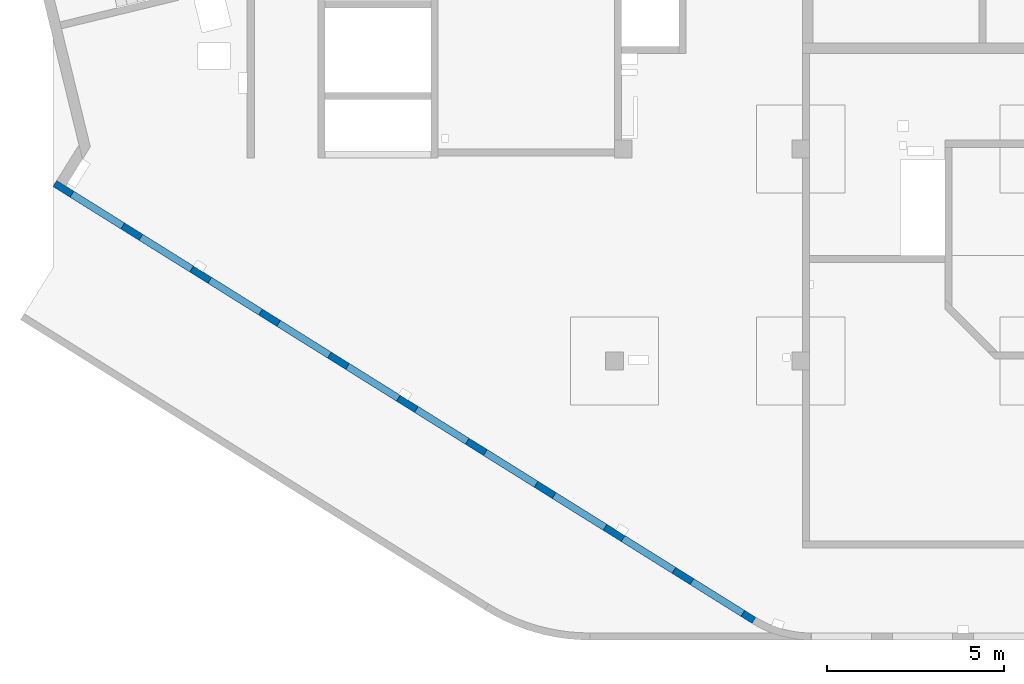
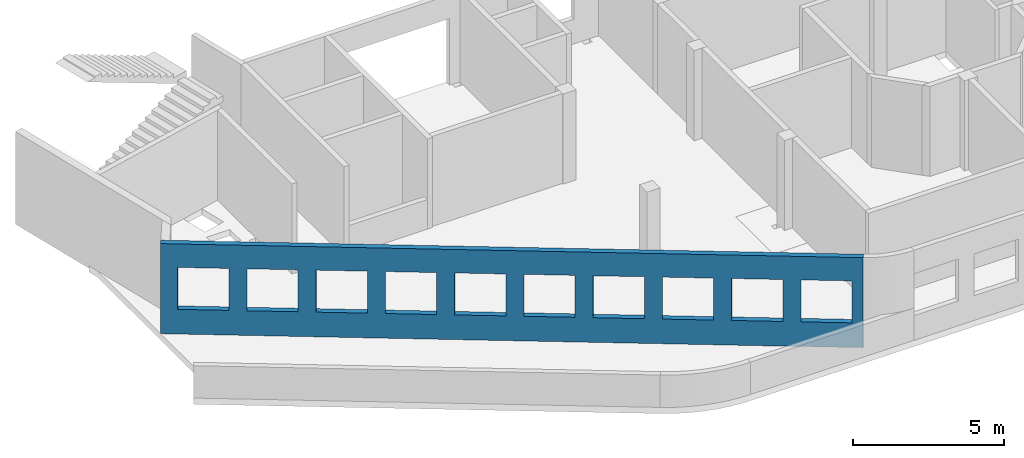
# One storey, part 7 of 10: 1 wall, 10 openings.
"""IFC4 building model written with IfcOpenShell, lengths in millimetres."""

from ifc_helpers import new_model, entity, si_unit, converted_unit, derived_unit, direction, frame, origin, place, context, subcontext, project, spatial, indexed_curve, outline, extrude, polygons, material, type_object, element, save


model = new_model("IFC4")

# Units and contexts
model_context = context("Model", 3, precision=0.01, world=origin(), true_north=direction((6.12303176911189e-17, 1.0)))
plan_context = context("Plan", 3, precision=0.01, world=origin(), true_north=direction((6.12303176911189e-17, 1.0)))
body_context = subcontext(model_context, "Body", "Model", "MODEL_VIEW")
ifc_project = project(units=[si_unit("LENGTHUNIT", "METRE", prefix="MILLI"), si_unit("AREAUNIT", "SQUARE_METRE"), si_unit("VOLUMEUNIT", "CUBIC_METRE"), converted_unit("PLANEANGLEUNIT", "DEGREE", entity("IfcRatioMeasure", 0.0174532925199433), si_unit("PLANEANGLEUNIT", "RADIAN"), dimensions=[0, 0, 0, 0, 0, 0, 0]), si_unit("MASSUNIT", "GRAM", prefix="KILO"), derived_unit("MASSDENSITYUNIT", [(si_unit("MASSUNIT", "GRAM", prefix="KILO"), 1), (si_unit("LENGTHUNIT", "METRE"), -3)]), derived_unit("MOMENTOFINERTIAUNIT", [(si_unit("LENGTHUNIT", "METRE"), 4)]), si_unit("TIMEUNIT", "SECOND"), si_unit("FREQUENCYUNIT", "HERTZ"), si_unit("THERMODYNAMICTEMPERATUREUNIT", "DEGREE_CELSIUS"), derived_unit("THERMALTRANSMITTANCEUNIT", [(si_unit("MASSUNIT", "GRAM", prefix="KILO"), 1), (si_unit("THERMODYNAMICTEMPERATUREUNIT", "KELVIN"), -1), (si_unit("TIMEUNIT", "SECOND"), -3)]), derived_unit("VOLUMETRICFLOWRATEUNIT", [(si_unit("LENGTHUNIT", "METRE"), 3), (si_unit("TIMEUNIT", "SECOND"), -1)]), derived_unit("MASSFLOWRATEUNIT", [(si_unit("MASSUNIT", "GRAM", prefix="KILO"), 1), (si_unit("TIMEUNIT", "SECOND"), -1)]), derived_unit("ROTATIONALFREQUENCYUNIT", [(si_unit("TIMEUNIT", "SECOND"), -1)]), si_unit("ELECTRICCURRENTUNIT", "AMPERE"), si_unit("ELECTRICVOLTAGEUNIT", "VOLT"), si_unit("POWERUNIT", "WATT"), si_unit("FORCEUNIT", "NEWTON", prefix="KILO"), si_unit("ILLUMINANCEUNIT", "LUX"), si_unit("LUMINOUSFLUXUNIT", "LUMEN"), si_unit("LUMINOUSINTENSITYUNIT", "CANDELA"), derived_unit("USERDEFINED", [(si_unit("MASSUNIT", "GRAM", prefix="KILO"), -1), (si_unit("LENGTHUNIT", "METRE"), -2), (si_unit("TIMEUNIT", "SECOND"), 3), (si_unit("LUMINOUSFLUXUNIT", "LUMEN"), 1)]), derived_unit("LINEARVELOCITYUNIT", [(si_unit("LENGTHUNIT", "METRE"), 1), (si_unit("TIMEUNIT", "SECOND"), -1)]), si_unit("PRESSUREUNIT", "PASCAL"), derived_unit("USERDEFINED", [(si_unit("LENGTHUNIT", "METRE"), -2), (si_unit("MASSUNIT", "GRAM", prefix="KILO"), 1), (si_unit("TIMEUNIT", "SECOND"), -2)]), derived_unit("LINEARFORCEUNIT", [(si_unit("MASSUNIT", "GRAM", prefix="KILO"), 1), (si_unit("LENGTHUNIT", "METRE"), 1), (si_unit("TIMEUNIT", "SECOND"), -2), (si_unit("LENGTHUNIT", "METRE"), -1)]), derived_unit("PLANARFORCEUNIT", [(si_unit("MASSUNIT", "GRAM", prefix="KILO"), 1), (si_unit("LENGTHUNIT", "METRE"), 1), (si_unit("TIMEUNIT", "SECOND"), -2), (si_unit("LENGTHUNIT", "METRE"), -2)])], contexts=[model_context, plan_context])

# Site, building, storey
site_placement = place(None, origin())
site = spatial("IfcSite", under=ifc_project, at=site_placement, CompositionType="ELEMENT")
building_placement = place(site_placement, origin())
building = spatial("IfcBuilding", under=site, at=building_placement, CompositionType="ELEMENT")
storey_placement = place(building_placement, frame((0.0, 0.0, 4200.0)))
storey = spatial("IfcBuildingStorey", under=building, at=storey_placement, CompositionType="ELEMENT", Elevation=4200.0)

# Wall, openings
ifc_material = material()
wall_type = type_object("IfcWallType", PredefinedType="STANDARD")
wall_placement = place(storey_placement, frame((19848.2602920667, 354.969733530519, -150.0), z_axis=(0.0, 0.0, 1.0), x_axis=(-0.848052743777572, 0.529911826412028, 0.0)))
wall = element("IfcWall", 1, at=wall_placement, inside=storey, type_object=wall_type, material=ifc_material, PredefinedType="NOTDEFINED", context=body_context, shape_type="Tessellation", body=[
    polygons([(372.190668142856, -100.000000000002, 2700.0), (2072.19066814286, -99.9999999999992, 2700.0), (2072.19066814286, -99.9999999999992, 1000.00000000001), (372.190668142856, -100.000000000002, 1000.00000000001), (2672.19066814286, -99.9999999999992, 2700.0), (4372.19066814286, -99.9999999999973, 2700.0), (4372.19066814286, -99.9999999999973, 1000.00000000001), (2672.19066814286, -99.9999999999992, 1000.00000000001), (4972.19066814287, -99.9999999999968, 2700.0), (6672.19066814287, -99.9999999999946, 2700.0), (6672.19066814287, -99.9999999999946, 1000.00000000001), (4972.19066814287, -99.9999999999968, 1000.00000000001), (7272.19066814288, -99.9999999999935, 2700.0), (8972.19066814288, -99.9999999999924, 2700.0), (8972.19066814288, -99.9999999999924, 1000.00000000001), (7272.19066814288, -99.9999999999935, 1000.00000000001), (9572.19066814288, -99.9999999999913, 2700.0), (11272.1906681429, -99.9999999999913, 2700.0), (11272.1906681429, -99.9999999999913, 1000.00000000001), (9572.19066814288, -99.9999999999913, 1000.00000000001), (11872.1906681429, -99.9999999999892, 2700.0), (13572.1906681429, -99.9999999999881, 2700.0), (13572.1906681429, -99.9999999999881, 1000.00000000001), (11872.1906681429, -99.9999999999892, 1000.00000000001), (14172.1906681429, -99.9999999999859, 2700.0), (15872.1906681429, -99.9999999999859, 2700.0), (15872.1906681429, -99.9999999999859, 1000.00000000001), (14172.1906681429, -99.9999999999859, 1000.00000000001), (16472.1906681429, -99.9999999999849, 2700.0), (18172.1906681429, -99.9999999999827, 2700.0), (18172.1906681429, -99.9999999999827, 1000.00000000001), (16472.1906681429, -99.9999999999849, 1000.00000000001), (18772.1906681429, -99.9999999999827, 2700.0), (20472.1906681429, -99.9999999999794, 2700.0), (20472.1906681429, -99.9999999999794, 1000.00000000001), (18772.1906681429, -99.9999999999827, 1000.00000000001), (21072.1906681429, -99.9999999999794, 2700.0), (22772.1906681429, -99.9999999999773, 2700.0), (22772.1906681429, -99.9999999999773, 1000.00000000001), (21072.1906681429, -99.9999999999794, 1000.00000000001), (0.970164127873786, -99.9999999999997, 5.41433564649196e-13), (23041.7760623233, -99.9999999999989, 5.41433564649196e-13), (23341.7760623233, -100.000000000001, 5.41433564649196e-13), (23341.7760623233, -99.9999999999989, 3650.0), (23041.7760623233, -99.9999999999989, 3650.0), (18772.1906681429, -100.0, 3650.0), (18472.188348855, -99.9999999999978, 3650.0), (14002.1883486828, -100.0, 3650.0), (13802.1857175861, -99.9999999999989, 3650.0), (4972.1865942764, -99.9999999999995, 3650.0), (4672.18834832425, -99.9999999999995, 3650.0), (297.188348155941, -99.9999999999986, 3650.0), (97.1857170592183, -99.9999999999997, 3650.0), (0.97016412787338, -99.999999999999, 3650.0), (3.14708259452345e-12, 100.000000000001, 5.41433564649196e-13), (-6.42952358020921e-13, 99.9999999999993, 3650.0), (23341.7760623233, 99.9999999999989, 3650.0), (23341.7760623233, 99.9999999999989, 5.41433564649196e-13), (2072.19066814285, 100.000000000319, 2700.0), (372.190668142856, 100.000000000318, 2700.0), (372.190668142856, 100.000000000318, 1000.00000000001), (2072.19066814285, 100.00000000032, 1000.00000000001), (4372.19066814286, 100.000000000324, 2700.0), (2672.19066814286, 100.00000000032, 2700.0), (2672.19066814286, 100.00000000032, 1000.00000000001), (4372.19066814286, 100.000000000324, 1000.00000000001), (6672.19066814287, 100.000000000325, 2700.0), (4972.19066814287, 100.000000000323, 2700.0), (4972.19066814287, 100.000000000323, 1000.00000000001), (6672.19066814287, 100.000000000325, 1000.00000000001), (8972.19066814287, 100.000000000329, 2700.0), (7272.19066814287, 100.000000000325, 2700.0), (7272.19066814287, 100.000000000325, 1000.00000000001), (8972.19066814287, 100.000000000329, 1000.00000000001), (11272.1906681429, 100.000000000329, 2700.0), (9572.19066814288, 100.000000000327, 2700.0), (9572.19066814288, 100.000000000327, 1000.00000000001), (11272.1906681429, 100.000000000329, 1000.00000000001), (13572.1906681429, 100.000000000332, 2700.0), (11872.1906681429, 100.000000000331, 2700.0), (11872.1906681429, 100.000000000331, 1000.00000000001), (13572.1906681429, 100.000000000332, 1000.00000000001), (15872.1906681429, 100.000000000336, 2700.0), (14172.1906681429, 100.000000000334, 2700.0), (14172.1906681429, 100.000000000334, 1000.00000000001), (15872.1906681429, 100.000000000336, 1000.00000000001), (18172.1906681429, 100.000000000337, 2700.0), (16472.1906681429, 100.000000000336, 2700.0), (16472.1906681429, 100.000000000336, 1000.00000000001), (18172.1906681429, 100.000000000337, 1000.00000000001), (20472.1906681429, 100.000000000339, 2700.0), (18772.1906681429, 100.000000000337, 2700.0), (18772.1906681429, 100.000000000338, 1000.00000000001), (20472.1906681429, 100.000000000338, 1000.00000000001), (22772.1906681429, 100.000000000343, 2700.0), (21072.1906681429, 100.00000000034, 2700.0), (21072.1906681429, 100.00000000034, 1000.00000000001), (22772.1906681429, 100.000000000343, 1000.00000000001)], [[[41, 42, 43, 44, 45, 46, 47, 48, 49, 50, 51, 52, 53, 54], [1, 2, 3, 4], [5, 6, 7, 8], [9, 10, 11, 12], [13, 14, 15, 16], [17, 18, 19, 20], [21, 22, 23, 24], [25, 26, 27, 28], [29, 30, 31, 32], [33, 34, 35, 36], [37, 38, 39, 40]], [[55, 56, 57, 58], [59, 60, 61, 62], [63, 64, 65, 66], [67, 68, 69, 70], [71, 72, 73, 74], [75, 76, 77, 78], [79, 80, 81, 82], [83, 84, 85, 86], [87, 88, 89, 90], [91, 92, 93, 94], [95, 96, 97, 98]], [[43, 42, 41, 55, 58]], [[54, 53, 52, 51, 50, 49, 48, 47, 46, 45, 44, 57, 56]], [[41, 54, 56, 55]], [[44, 43, 58, 57]], [[60, 59, 2, 1]], [[60, 1, 4, 61]], [[61, 4, 3, 62]], [[2, 59, 62, 3]], [[64, 63, 6, 5]], [[64, 5, 8, 65]], [[65, 8, 7, 66]], [[6, 63, 66, 7]], [[68, 67, 10, 9]], [[68, 9, 12, 69]], [[69, 12, 11, 70]], [[10, 67, 70, 11]], [[72, 71, 14, 13]], [[72, 13, 16, 73]], [[73, 16, 15, 74]], [[14, 71, 74, 15]], [[76, 75, 18, 17]], [[76, 17, 20, 77]], [[77, 20, 19, 78]], [[18, 75, 78, 19]], [[80, 79, 22, 21]], [[80, 21, 24, 81]], [[81, 24, 23, 82]], [[22, 79, 82, 23]], [[84, 83, 26, 25]], [[84, 25, 28, 85]], [[85, 28, 27, 86]], [[26, 83, 86, 27]], [[88, 87, 30, 29]], [[88, 29, 32, 89]], [[89, 32, 31, 90]], [[30, 87, 90, 31]], [[92, 91, 34, 33]], [[92, 33, 36, 93]], [[93, 36, 35, 94]], [[34, 91, 94, 35]], [[96, 95, 38, 37]], [[96, 37, 40, 97]], [[97, 40, 39, 98]], [[38, 95, 98, 39]]], closed=True),
])
opening_1_placement = place(wall_placement, frame((16644.2689400824, 10818.8609189489, 150.0), z_axis=(0.0, 0.0, 1.0), x_axis=(-0.848052743777572, -0.529911826412028, 0.0)))
element("IfcOpeningElement", 2, at=opening_1_placement, cuts=wall, PredefinedType="OPENING", context=body_context, shape_type="SweptSolid", body=[
    extrude(outline(indexed_curve([(-849.999999999994, -850.0), (849.999999999993, -850.0), (849.999999999993, 850.0), (-849.999999999994, 850.0), (-849.999999999994, -850.0)], self_intersect=False)), frame((1310.07752897417, 12056.6031038165, 1700.0), z_axis=(-0.529911826412026, -0.848052743777574, 0.0), x_axis=(0.0, 0.0, -1.0)), (0.0, 0.0, 1.0), 200.000000000959),
])
opening_2_placement = place(wall_placement, frame((16644.2689400824, 10818.8609189489, 150.0), z_axis=(0.0, 0.0, 1.0), x_axis=(-0.848052743777572, -0.529911826412028, 0.0)))
element("IfcOpeningElement", 3, at=opening_2_placement, cuts=wall, PredefinedType="OPENING", context=body_context, shape_type="SweptSolid", body=[
    extrude(outline(indexed_curve([(-849.999999999994, -850.0), (849.999999999993, -850.0), (849.999999999993, 850.0), (-849.999999999994, 850.0), (-849.999999999994, -850.0)], self_intersect=False)), frame((3260.5988396626, 10837.8059030689, 1700.0), z_axis=(-0.529911826412026, -0.848052743777574, 0.0), x_axis=(0.0, 0.0, -1.0)), (0.0, 0.0, 1.0), 200.000000000962),
])
opening_3_placement = place(wall_placement, frame((16644.2689400824, 10818.8609189489, 150.0), z_axis=(0.0, 0.0, 1.0), x_axis=(-0.848052743777572, -0.529911826412028, 0.0)))
element("IfcOpeningElement", 4, at=opening_3_placement, cuts=wall, PredefinedType="OPENING", context=body_context, shape_type="SweptSolid", body=[
    extrude(outline(indexed_curve([(-849.999999999994, -850.0), (849.999999999993, -850.0), (849.999999999993, 850.0), (-849.999999999994, 850.0), (-849.999999999994, -850.0)], self_intersect=False)), frame((5211.12015035101, 9619.00870232123, 1700.0), z_axis=(-0.529911826412025, -0.848052743777574, 0.0), x_axis=(0.0, 0.0, -1.0)), (0.0, 0.0, 1.0), 200.000000000962),
])
opening_4_placement = place(wall_placement, frame((16644.2689400824, 10818.8609189489, 150.0), z_axis=(0.0, 0.0, 1.0), x_axis=(-0.848052743777572, -0.529911826412028, 0.0)))
element("IfcOpeningElement", 5, at=opening_4_placement, cuts=wall, PredefinedType="OPENING", context=body_context, shape_type="SweptSolid", body=[
    extrude(outline(indexed_curve([(-849.999999999994, -849.999999999999), (849.999999999993, -849.999999999999), (849.999999999993, 850.0), (-849.999999999994, 850.0), (-849.999999999994, -849.999999999999)], self_intersect=False)), frame((7161.64146103944, 8400.21150157357, 1700.0), z_axis=(-0.529911826412026, -0.848052743777574, 0.0), x_axis=(0.0, 0.0, -1.0)), (0.0, 0.0, 1.0), 200.000000000964),
])
opening_5_placement = place(wall_placement, frame((16644.2689400824, 10818.8609189489, 150.0), z_axis=(0.0, 0.0, 1.0), x_axis=(-0.848052743777572, -0.529911826412028, 0.0)))
element("IfcOpeningElement", 6, at=opening_5_placement, cuts=wall, PredefinedType="OPENING", context=body_context, shape_type="SweptSolid", body=[
    extrude(outline(indexed_curve([(-849.999999999994, -849.999999999999), (849.999999999993, -849.999999999999), (849.999999999993, 850.0), (-849.999999999994, 850.0), (-849.999999999994, -849.999999999999)], self_intersect=False)), frame((9112.16277172786, 7181.41430082591, 1700.0), z_axis=(-0.529911826412026, -0.848052743777574, 0.0), x_axis=(0.0, 0.0, -1.0)), (0.0, 0.0, 1.0), 200.000000000964),
])
opening_6_placement = place(wall_placement, frame((16644.2689400824, 10818.8609189489, 150.0), z_axis=(0.0, 0.0, 1.0), x_axis=(-0.848052743777572, -0.529911826412028, 0.0)))
element("IfcOpeningElement", 7, at=opening_6_placement, cuts=wall, PredefinedType="OPENING", context=body_context, shape_type="SweptSolid", body=[
    extrude(outline(indexed_curve([(-849.999999999994, -850.0), (849.999999999993, -850.0), (849.999999999993, 850.0), (-849.999999999994, 850.0), (-849.999999999994, -850.0)], self_intersect=False)), frame((11062.6840824163, 5962.61710007824, 1700.0), z_axis=(-0.529911826412025, -0.848052743777574, 0.0), x_axis=(0.0, 0.0, -1.0)), (0.0, 0.0, 1.0), 200.000000000964),
])
opening_7_placement = place(wall_placement, frame((16644.2689400824, 10818.8609189489, 150.0), z_axis=(0.0, 0.0, 1.0), x_axis=(-0.848052743777572, -0.529911826412028, 0.0)))
element("IfcOpeningElement", 8, at=opening_7_placement, cuts=wall, PredefinedType="OPENING", context=body_context, shape_type="SweptSolid", body=[
    extrude(outline(indexed_curve([(-849.999999999994, -850.0), (849.999999999993, -850.0), (849.999999999993, 850.0), (-849.999999999994, 850.0), (-849.999999999994, -850.0)], self_intersect=False)), frame((13013.2053931047, 4743.81989933058, 1700.0), z_axis=(-0.529911826412025, -0.848052743777574, 0.0), x_axis=(0.0, 0.0, -1.0)), (0.0, 0.0, 1.0), 200.000000000962),
])
opening_8_placement = place(wall_placement, frame((16644.2689400824, 10818.8609189489, 150.0), z_axis=(0.0, 0.0, 1.0), x_axis=(-0.848052743777572, -0.529911826412028, 0.0)))
element("IfcOpeningElement", 9, at=opening_8_placement, cuts=wall, PredefinedType="OPENING", context=body_context, shape_type="SweptSolid", body=[
    extrude(outline(indexed_curve([(-849.999999999994, -850.000000000002), (849.999999999993, -850.000000000002), (849.999999999993, 849.999999999998), (-849.999999999994, 849.999999999998), (-849.999999999994, -850.000000000002)], self_intersect=False)), frame((14963.7267037931, 3525.02269858292, 1700.0), z_axis=(-0.529911826412025, -0.848052743777574, 0.0), x_axis=(0.0, 0.0, -1.0)), (0.0, 0.0, 1.0), 200.000000000962),
])
opening_9_placement = place(wall_placement, frame((16644.2689400824, 10818.8609189489, 150.0), z_axis=(0.0, 0.0, 1.0), x_axis=(-0.848052743777572, -0.529911826412028, 0.0)))
element("IfcOpeningElement", 10, at=opening_9_placement, cuts=wall, PredefinedType="OPENING", context=body_context, shape_type="SweptSolid", body=[
    extrude(outline(indexed_curve([(-849.999999999994, -850.0), (849.999999999993, -850.0), (849.999999999993, 850.0), (-849.999999999994, 850.0), (-849.999999999994, -850.0)], self_intersect=False)), frame((16914.2480144816, 2306.22549783526, 1700.0), z_axis=(-0.529911826412025, -0.848052743777574, 0.0), x_axis=(0.0, 0.0, -1.0)), (0.0, 0.0, 1.0), 200.000000000962),
])
opening_10_placement = place(wall_placement, frame((16644.2689400824, 10818.8609189489, 150.0), z_axis=(0.0, 0.0, 1.0), x_axis=(-0.848052743777572, -0.529911826412028, 0.0)))
element("IfcOpeningElement", 11, at=opening_10_placement, cuts=wall, PredefinedType="OPENING", context=body_context, shape_type="SweptSolid", body=[
    extrude(outline(indexed_curve([(-849.999999999994, -850.0), (849.999999999993, -850.0), (849.999999999993, 850.0), (-849.999999999994, 850.0), (-849.999999999994, -850.0)], self_intersect=False)), frame((18864.76932517, 1087.4282970876, 1700.0), z_axis=(-0.529911826412025, -0.848052743777574, 0.0), x_axis=(0.0, 0.0, -1.0)), (0.0, 0.0, 1.0), 200.000000000966),
])

save(model, "model.ifc")
